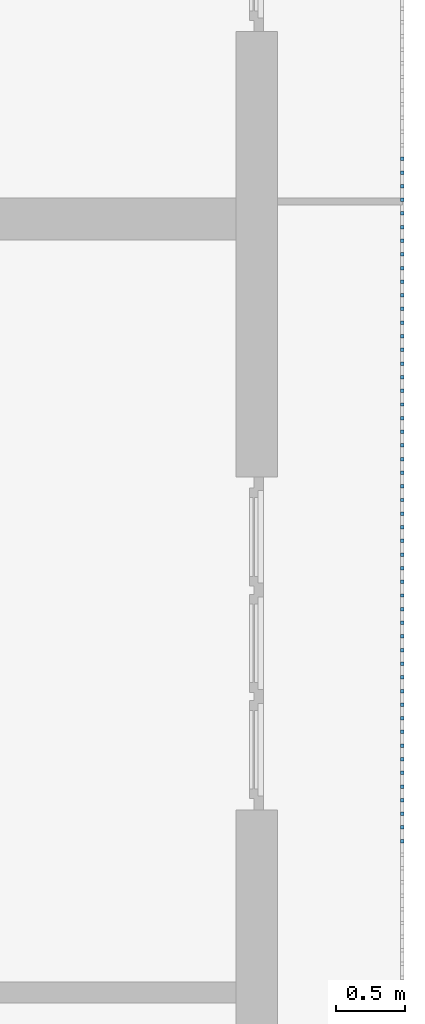
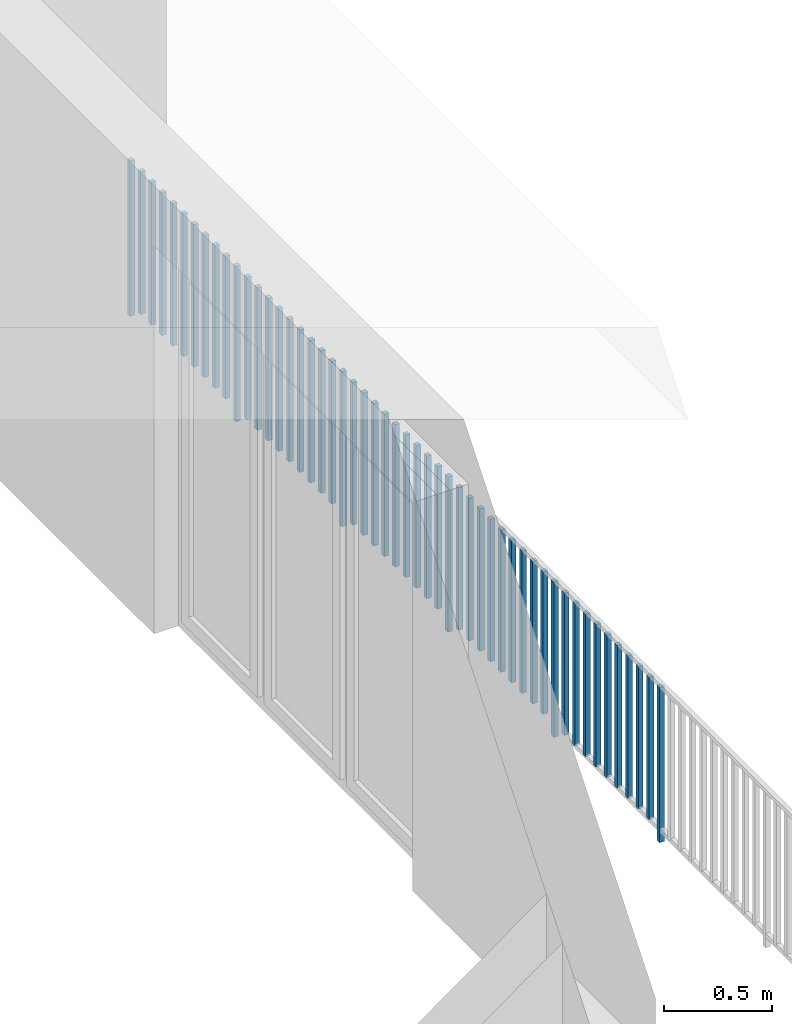
# One storey, part 45 of 54: 51 building element parts, 1 element without a shape of its own.
"""IFC4 building model written with IfcOpenShell, lengths in metres."""

from ifc_helpers import new_model, entity, si_unit, converted_unit, derived_unit, direction, frame, origin_with_axes, place, context, subcontext, project, spatial, polygons, material, type_object, element, aggregate, save


model = new_model("IFC4")

# Units and contexts
model_context = context("Model", 3, precision=1e-05, world=origin_with_axes(), true_north=direction((0.0, 1.0)))
body_context = subcontext(model_context, "Body", "Model", "MODEL_VIEW")
ifc_project = project(units=[si_unit("LENGTHUNIT", "METRE"), si_unit("AREAUNIT", "SQUARE_METRE"), si_unit("VOLUMEUNIT", "CUBIC_METRE"), converted_unit("PLANEANGLEUNIT", "DEGREE", entity("IfcPlaneAngleMeasure", 0.0174532925199), si_unit("PLANEANGLEUNIT", "RADIAN"), dimensions=[0, 0, 0, 0, 0, 0, 0]), converted_unit("TIMEUNIT", "Year", entity("IfcTimeMeasure", 31556926.0), si_unit("TIMEUNIT", "SECOND"), dimensions=[0, 0, 1, 0, 0, 0, 0]), si_unit("MASSUNIT", "GRAM", prefix="KILO"), si_unit("THERMODYNAMICTEMPERATUREUNIT", "DEGREE_CELSIUS"), si_unit("LUMINOUSINTENSITYUNIT", "LUMEN"), si_unit("ENERGYUNIT", "JOULE", prefix="MEGA"), derived_unit("THERMALCONDUCTANCEUNIT", [(si_unit("POWERUNIT", "WATT"), 1), (si_unit("LENGTHUNIT", "METRE"), -1), (si_unit("THERMODYNAMICTEMPERATUREUNIT", "KELVIN"), -1)]), derived_unit("SPECIFICHEATCAPACITYUNIT", [(si_unit("ENERGYUNIT", "JOULE"), 1), (si_unit("MASSUNIT", "GRAM", prefix="KILO"), -1), (si_unit("THERMODYNAMICTEMPERATUREUNIT", "KELVIN"), -1)]), derived_unit("MASSDENSITYUNIT", [(si_unit("MASSUNIT", "GRAM", prefix="KILO"), 1), (si_unit("VOLUMEUNIT", "CUBIC_METRE"), -1)])], contexts=[model_context])

# Site, building, storey, space
site_placement = place(None, origin_with_axes())
site = spatial("IfcSite", under=ifc_project, at=site_placement, CompositionType="ELEMENT")
building_placement = place(site_placement, origin_with_axes())
building = spatial("IfcBuilding", under=site, at=building_placement, CompositionType="ELEMENT")
storey_placement = place(building_placement, frame((0.0, 0.0, 6.29), z_axis=(0.0, 0.0, 1.0), x_axis=(1.0, 0.0, 0.0)))
storey = spatial("IfcBuildingStorey", under=building, at=storey_placement, Name="2. Geschoss", CompositionType="ELEMENT", Elevation=6.29)
space_placement = place(storey_placement, frame((10.2378006196, 9.82118769833, 0.0), z_axis=(0.0, 0.0, 1.0), x_axis=(-1.0, 0.0, 0.0)))
space = spatial("IfcSpace", under=storey, at=space_placement, CompositionType="ELEMENT", PredefinedType="EXTERNAL")

# Railing, building element parts
railing_type = type_object("IfcRailingType", PredefinedType="NOTDEFINED")
railing_placement = place(space_placement, frame((0.0, -7.06315681498e-08, 0.0), z_axis=(0.0, 0.0, 1.0), x_axis=(-1.0, 0.0, 0.0)))
railing = element("IfcRailing", 1, at=railing_placement, inside=space, type_object=railing_type, PredefinedType="NOTDEFINED")
ifc_material = material()
building_element_part_1_placement = place(railing_placement, origin_with_axes())
building_element_part_1 = element("IfcBuildingElementPart", 2, at=building_element_part_1_placement, material=ifc_material, PredefinedType="NOTDEFINED", context=body_context, shape_type="Tessellation", body=[
    polygons([(0.0125, -12.7708333333, 0.0), (-0.0125, -12.7708333333, 0.0), (-0.0125, -12.7708333333, 0.88), (0.0125, -12.7708333333, 0.88), (0.0125, -12.7958333333, 0.0), (-0.0125, -12.7958333333, 0.0), (-0.0125, -12.7958333333, 0.88), (0.0125, -12.7958333333, 0.88)], [[[1, 2, 3, 4]], [[1, 5, 6, 2]], [[2, 6, 7, 3]], [[4, 3, 7, 8]], [[5, 1, 4, 8]], [[6, 5, 8, 7]]], closed=True),
])
building_element_part_2_placement = place(railing_placement, origin_with_axes())
building_element_part_2 = element("IfcBuildingElementPart", 3, at=building_element_part_2_placement, material=ifc_material, PredefinedType="NOTDEFINED", context=body_context, shape_type="Tessellation", body=[
    polygons([(0.0125, -12.6725, 0.07), (-0.0125, -12.6725, 0.07), (-0.0125, -12.6725, 0.8775), (0.0125, -12.6725, 0.8775), (0.0125, -12.6975, 0.07), (-0.0125, -12.6975, 0.07), (-0.0125, -12.6975, 0.8775), (0.0125, -12.6975, 0.8775)], [[[1, 2, 3, 4]], [[1, 5, 6, 2]], [[2, 6, 7, 3]], [[4, 3, 7, 8]], [[5, 1, 4, 8]], [[6, 5, 8, 7]]], closed=True),
])
building_element_part_3_placement = place(railing_placement, origin_with_axes())
building_element_part_3 = element("IfcBuildingElementPart", 4, at=building_element_part_3_placement, material=ifc_material, PredefinedType="NOTDEFINED", context=body_context, shape_type="Tessellation", body=[
    polygons([(0.0125, -12.5741666667, 0.07), (-0.0125, -12.5741666667, 0.07), (-0.0125, -12.5741666667, 0.8775), (0.0125, -12.5741666667, 0.8775), (0.0125, -12.5991666667, 0.07), (-0.0125, -12.5991666667, 0.07), (-0.0125, -12.5991666667, 0.8775), (0.0125, -12.5991666667, 0.8775)], [[[1, 2, 3, 4]], [[1, 5, 6, 2]], [[2, 6, 7, 3]], [[4, 3, 7, 8]], [[5, 1, 4, 8]], [[6, 5, 8, 7]]], closed=True),
])
building_element_part_4_placement = place(railing_placement, origin_with_axes())
building_element_part_4 = element("IfcBuildingElementPart", 5, at=building_element_part_4_placement, material=ifc_material, PredefinedType="NOTDEFINED", context=body_context, shape_type="Tessellation", body=[
    polygons([(0.0125, -12.4758333333, 0.07), (-0.0125, -12.4758333333, 0.07), (-0.0125, -12.4758333333, 0.8775), (0.0125, -12.4758333333, 0.8775), (0.0125, -12.5008333333, 0.07), (-0.0125, -12.5008333333, 0.07), (-0.0125, -12.5008333333, 0.8775), (0.0125, -12.5008333333, 0.8775)], [[[1, 2, 3, 4]], [[1, 5, 6, 2]], [[2, 6, 7, 3]], [[4, 3, 7, 8]], [[5, 1, 4, 8]], [[6, 5, 8, 7]]], closed=True),
])
building_element_part_5_placement = place(railing_placement, origin_with_axes())
building_element_part_5 = element("IfcBuildingElementPart", 6, at=building_element_part_5_placement, material=ifc_material, PredefinedType="NOTDEFINED", context=body_context, shape_type="Tessellation", body=[
    polygons([(0.0125, -12.3775, 0.07), (-0.0125, -12.3775, 0.07), (-0.0125, -12.3775, 0.8775), (0.0125, -12.3775, 0.8775), (0.0125, -12.4025, 0.07), (-0.0125, -12.4025, 0.07), (-0.0125, -12.4025, 0.8775), (0.0125, -12.4025, 0.8775)], [[[1, 2, 3, 4]], [[1, 5, 6, 2]], [[2, 6, 7, 3]], [[4, 3, 7, 8]], [[5, 1, 4, 8]], [[6, 5, 8, 7]]], closed=True),
])
building_element_part_6_placement = place(railing_placement, origin_with_axes())
building_element_part_6 = element("IfcBuildingElementPart", 7, at=building_element_part_6_placement, material=ifc_material, PredefinedType="NOTDEFINED", context=body_context, shape_type="Tessellation", body=[
    polygons([(0.0125, -12.2791666667, 0.07), (-0.0125, -12.2791666667, 0.07), (-0.0125, -12.2791666667, 0.8775), (0.0125, -12.2791666667, 0.8775), (0.0125, -12.3041666667, 0.07), (-0.0125, -12.3041666667, 0.07), (-0.0125, -12.3041666667, 0.8775), (0.0125, -12.3041666667, 0.8775)], [[[1, 2, 3, 4]], [[1, 5, 6, 2]], [[2, 6, 7, 3]], [[4, 3, 7, 8]], [[5, 1, 4, 8]], [[6, 5, 8, 7]]], closed=True),
])
building_element_part_7_placement = place(railing_placement, origin_with_axes())
building_element_part_7 = element("IfcBuildingElementPart", 8, at=building_element_part_7_placement, material=ifc_material, PredefinedType="NOTDEFINED", context=body_context, shape_type="Tessellation", body=[
    polygons([(0.0125, -12.1808333333, 0.07), (-0.0125, -12.1808333333, 0.07), (-0.0125, -12.1808333333, 0.8775), (0.0125, -12.1808333333, 0.8775), (0.0125, -12.2058333333, 0.07), (-0.0125, -12.2058333333, 0.07), (-0.0125, -12.2058333333, 0.8775), (0.0125, -12.2058333333, 0.8775)], [[[1, 2, 3, 4]], [[1, 5, 6, 2]], [[2, 6, 7, 3]], [[4, 3, 7, 8]], [[5, 1, 4, 8]], [[6, 5, 8, 7]]], closed=True),
])
building_element_part_8_placement = place(railing_placement, origin_with_axes())
building_element_part_8 = element("IfcBuildingElementPart", 9, at=building_element_part_8_placement, material=ifc_material, PredefinedType="NOTDEFINED", context=body_context, shape_type="Tessellation", body=[
    polygons([(0.0125, -12.0825, 0.07), (-0.0125, -12.0825, 0.07), (-0.0125, -12.0825, 0.8775), (0.0125, -12.0825, 0.8775), (0.0125, -12.1075, 0.07), (-0.0125, -12.1075, 0.07), (-0.0125, -12.1075, 0.8775), (0.0125, -12.1075, 0.8775)], [[[1, 2, 3, 4]], [[1, 5, 6, 2]], [[2, 6, 7, 3]], [[4, 3, 7, 8]], [[5, 1, 4, 8]], [[6, 5, 8, 7]]], closed=True),
])
building_element_part_9_placement = place(railing_placement, origin_with_axes())
building_element_part_9 = element("IfcBuildingElementPart", 10, at=building_element_part_9_placement, material=ifc_material, PredefinedType="NOTDEFINED", context=body_context, shape_type="Tessellation", body=[
    polygons([(0.0125, -11.9841666667, 0.07), (-0.0125, -11.9841666667, 0.07), (-0.0125, -11.9841666667, 0.8775), (0.0125, -11.9841666667, 0.8775), (0.0125, -12.0091666667, 0.07), (-0.0125, -12.0091666667, 0.07), (-0.0125, -12.0091666667, 0.8775), (0.0125, -12.0091666667, 0.8775)], [[[1, 2, 3, 4]], [[1, 5, 6, 2]], [[2, 6, 7, 3]], [[4, 3, 7, 8]], [[5, 1, 4, 8]], [[6, 5, 8, 7]]], closed=True),
])
building_element_part_10_placement = place(railing_placement, origin_with_axes())
building_element_part_10 = element("IfcBuildingElementPart", 11, at=building_element_part_10_placement, material=ifc_material, PredefinedType="NOTDEFINED", context=body_context, shape_type="Tessellation", body=[
    polygons([(0.0125, -11.8858333333, 0.07), (-0.0125, -11.8858333333, 0.07), (-0.0125, -11.8858333333, 0.8775), (0.0125, -11.8858333333, 0.8775), (0.0125, -11.9108333333, 0.07), (-0.0125, -11.9108333333, 0.07), (-0.0125, -11.9108333333, 0.8775), (0.0125, -11.9108333333, 0.8775)], [[[1, 2, 3, 4]], [[1, 5, 6, 2]], [[2, 6, 7, 3]], [[4, 3, 7, 8]], [[5, 1, 4, 8]], [[6, 5, 8, 7]]], closed=True),
])
building_element_part_11_placement = place(railing_placement, origin_with_axes())
building_element_part_11 = element("IfcBuildingElementPart", 12, at=building_element_part_11_placement, material=ifc_material, PredefinedType="NOTDEFINED", context=body_context, shape_type="Tessellation", body=[
    polygons([(0.0125, -11.7875, 0.0), (-0.0125, -11.7875, 0.0), (-0.0125, -11.7875, 0.88), (0.0125, -11.7875, 0.88), (0.0125, -11.8125, 0.0), (-0.0125, -11.8125, 0.0), (-0.0125, -11.8125, 0.88), (0.0125, -11.8125, 0.88)], [[[1, 2, 3, 4]], [[1, 5, 6, 2]], [[2, 6, 7, 3]], [[4, 3, 7, 8]], [[5, 1, 4, 8]], [[6, 5, 8, 7]]], closed=True),
])
building_element_part_12_placement = place(railing_placement, origin_with_axes())
building_element_part_12 = element("IfcBuildingElementPart", 13, at=building_element_part_12_placement, material=ifc_material, PredefinedType="NOTDEFINED", context=body_context, shape_type="Tessellation", body=[
    polygons([(0.0125, -11.6891666667, 0.07), (-0.0125, -11.6891666667, 0.07), (-0.0125, -11.6891666667, 0.8775), (0.0125, -11.6891666667, 0.8775), (0.0125, -11.7141666667, 0.07), (-0.0125, -11.7141666667, 0.07), (-0.0125, -11.7141666667, 0.8775), (0.0125, -11.7141666667, 0.8775)], [[[1, 2, 3, 4]], [[1, 5, 6, 2]], [[2, 6, 7, 3]], [[4, 3, 7, 8]], [[5, 1, 4, 8]], [[6, 5, 8, 7]]], closed=True),
])
building_element_part_13_placement = place(railing_placement, origin_with_axes())
building_element_part_13 = element("IfcBuildingElementPart", 14, at=building_element_part_13_placement, material=ifc_material, PredefinedType="NOTDEFINED", context=body_context, shape_type="Tessellation", body=[
    polygons([(0.0125, -11.5908333333, 0.07), (-0.0125, -11.5908333333, 0.07), (-0.0125, -11.5908333333, 0.8775), (0.0125, -11.5908333333, 0.8775), (0.0125, -11.6158333333, 0.07), (-0.0125, -11.6158333333, 0.07), (-0.0125, -11.6158333333, 0.8775), (0.0125, -11.6158333333, 0.8775)], [[[1, 2, 3, 4]], [[1, 5, 6, 2]], [[2, 6, 7, 3]], [[4, 3, 7, 8]], [[5, 1, 4, 8]], [[6, 5, 8, 7]]], closed=True),
])
building_element_part_14_placement = place(railing_placement, origin_with_axes())
building_element_part_14 = element("IfcBuildingElementPart", 15, at=building_element_part_14_placement, material=ifc_material, PredefinedType="NOTDEFINED", context=body_context, shape_type="Tessellation", body=[
    polygons([(0.0125, -11.4925, 0.07), (-0.0125, -11.4925, 0.07), (-0.0125, -11.4925, 0.8775), (0.0125, -11.4925, 0.8775), (0.0125, -11.5175, 0.07), (-0.0125, -11.5175, 0.07), (-0.0125, -11.5175, 0.8775), (0.0125, -11.5175, 0.8775)], [[[1, 2, 3, 4]], [[1, 5, 6, 2]], [[2, 6, 7, 3]], [[4, 3, 7, 8]], [[5, 1, 4, 8]], [[6, 5, 8, 7]]], closed=True),
])
building_element_part_15_placement = place(railing_placement, origin_with_axes())
building_element_part_15 = element("IfcBuildingElementPart", 16, at=building_element_part_15_placement, material=ifc_material, PredefinedType="NOTDEFINED", context=body_context, shape_type="Tessellation", body=[
    polygons([(0.0125, -11.3941666667, 0.07), (-0.0125, -11.3941666667, 0.07), (-0.0125, -11.3941666667, 0.8775), (0.0125, -11.3941666667, 0.8775), (0.0125, -11.4191666667, 0.07), (-0.0125, -11.4191666667, 0.07), (-0.0125, -11.4191666667, 0.8775), (0.0125, -11.4191666667, 0.8775)], [[[1, 2, 3, 4]], [[1, 5, 6, 2]], [[2, 6, 7, 3]], [[4, 3, 7, 8]], [[5, 1, 4, 8]], [[6, 5, 8, 7]]], closed=True),
])
building_element_part_16_placement = place(railing_placement, origin_with_axes())
building_element_part_16 = element("IfcBuildingElementPart", 17, at=building_element_part_16_placement, material=ifc_material, PredefinedType="NOTDEFINED", context=body_context, shape_type="Tessellation", body=[
    polygons([(0.0125, -11.2958333333, 0.07), (-0.0125, -11.2958333333, 0.07), (-0.0125, -11.2958333333, 0.8775), (0.0125, -11.2958333333, 0.8775), (0.0125, -11.3208333333, 0.07), (-0.0125, -11.3208333333, 0.07), (-0.0125, -11.3208333333, 0.8775), (0.0125, -11.3208333333, 0.8775)], [[[1, 2, 3, 4]], [[1, 5, 6, 2]], [[2, 6, 7, 3]], [[4, 3, 7, 8]], [[5, 1, 4, 8]], [[6, 5, 8, 7]]], closed=True),
])
building_element_part_17_placement = place(railing_placement, origin_with_axes())
building_element_part_17 = element("IfcBuildingElementPart", 18, at=building_element_part_17_placement, material=ifc_material, PredefinedType="NOTDEFINED", context=body_context, shape_type="Tessellation", body=[
    polygons([(0.0125, -11.1975, 0.07), (-0.0125, -11.1975, 0.07), (-0.0125, -11.1975, 0.8775), (0.0125, -11.1975, 0.8775), (0.0125, -11.2225, 0.07), (-0.0125, -11.2225, 0.07), (-0.0125, -11.2225, 0.8775), (0.0125, -11.2225, 0.8775)], [[[1, 2, 3, 4]], [[1, 5, 6, 2]], [[2, 6, 7, 3]], [[4, 3, 7, 8]], [[5, 1, 4, 8]], [[6, 5, 8, 7]]], closed=True),
])
building_element_part_18_placement = place(railing_placement, origin_with_axes())
building_element_part_18 = element("IfcBuildingElementPart", 19, at=building_element_part_18_placement, material=ifc_material, PredefinedType="NOTDEFINED", context=body_context, shape_type="Tessellation", body=[
    polygons([(0.0125, -11.0991666667, 0.07), (-0.0125, -11.0991666667, 0.07), (-0.0125, -11.0991666667, 0.8775), (0.0125, -11.0991666667, 0.8775), (0.0125, -11.1241666667, 0.07), (-0.0125, -11.1241666667, 0.07), (-0.0125, -11.1241666667, 0.8775), (0.0125, -11.1241666667, 0.8775)], [[[1, 2, 3, 4]], [[1, 5, 6, 2]], [[2, 6, 7, 3]], [[4, 3, 7, 8]], [[5, 1, 4, 8]], [[6, 5, 8, 7]]], closed=True),
])
building_element_part_19_placement = place(railing_placement, origin_with_axes())
building_element_part_19 = element("IfcBuildingElementPart", 20, at=building_element_part_19_placement, material=ifc_material, PredefinedType="NOTDEFINED", context=body_context, shape_type="Tessellation", body=[
    polygons([(0.0125, -11.0008333333, 0.07), (-0.0125, -11.0008333333, 0.07), (-0.0125, -11.0008333333, 0.8775), (0.0125, -11.0008333333, 0.8775), (0.0125, -11.0258333333, 0.07), (-0.0125, -11.0258333333, 0.07), (-0.0125, -11.0258333333, 0.8775), (0.0125, -11.0258333333, 0.8775)], [[[1, 2, 3, 4]], [[1, 5, 6, 2]], [[2, 6, 7, 3]], [[4, 3, 7, 8]], [[5, 1, 4, 8]], [[6, 5, 8, 7]]], closed=True),
])
building_element_part_20_placement = place(railing_placement, origin_with_axes())
building_element_part_20 = element("IfcBuildingElementPart", 21, at=building_element_part_20_placement, material=ifc_material, PredefinedType="NOTDEFINED", context=body_context, shape_type="Tessellation", body=[
    polygons([(0.0125, -10.9025, 0.07), (-0.0125, -10.9025, 0.07), (-0.0125, -10.9025, 0.8775), (0.0125, -10.9025, 0.8775), (0.0125, -10.9275, 0.07), (-0.0125, -10.9275, 0.07), (-0.0125, -10.9275, 0.8775), (0.0125, -10.9275, 0.8775)], [[[1, 2, 3, 4]], [[1, 5, 6, 2]], [[2, 6, 7, 3]], [[4, 3, 7, 8]], [[5, 1, 4, 8]], [[6, 5, 8, 7]]], closed=True),
])
building_element_part_21_placement = place(railing_placement, origin_with_axes())
building_element_part_21 = element("IfcBuildingElementPart", 22, at=building_element_part_21_placement, material=ifc_material, PredefinedType="NOTDEFINED", context=body_context, shape_type="Tessellation", body=[
    polygons([(0.0125, -10.8041666667, 0.0), (-0.0125, -10.8041666667, 0.0), (-0.0125, -10.8041666667, 0.88), (0.0125, -10.8041666667, 0.88), (0.0125, -10.8291666667, 0.0), (-0.0125, -10.8291666667, 0.0), (-0.0125, -10.8291666667, 0.88), (0.0125, -10.8291666667, 0.88)], [[[1, 2, 3, 4]], [[1, 5, 6, 2]], [[2, 6, 7, 3]], [[4, 3, 7, 8]], [[5, 1, 4, 8]], [[6, 5, 8, 7]]], closed=True),
])
building_element_part_22_placement = place(railing_placement, origin_with_axes())
building_element_part_22 = element("IfcBuildingElementPart", 23, at=building_element_part_22_placement, material=ifc_material, PredefinedType="NOTDEFINED", context=body_context, shape_type="Tessellation", body=[
    polygons([(0.0125, -10.7058333333, 0.07), (-0.0125, -10.7058333333, 0.07), (-0.0125, -10.7058333333, 0.8775), (0.0125, -10.7058333333, 0.8775), (0.0125, -10.7308333333, 0.07), (-0.0125, -10.7308333333, 0.07), (-0.0125, -10.7308333333, 0.8775), (0.0125, -10.7308333333, 0.8775)], [[[1, 2, 3, 4]], [[1, 5, 6, 2]], [[2, 6, 7, 3]], [[4, 3, 7, 8]], [[5, 1, 4, 8]], [[6, 5, 8, 7]]], closed=True),
])
building_element_part_23_placement = place(railing_placement, origin_with_axes())
building_element_part_23 = element("IfcBuildingElementPart", 24, at=building_element_part_23_placement, material=ifc_material, PredefinedType="NOTDEFINED", context=body_context, shape_type="Tessellation", body=[
    polygons([(0.0125, -10.6075, 0.07), (-0.0125, -10.6075, 0.07), (-0.0125, -10.6075, 0.8775), (0.0125, -10.6075, 0.8775), (0.0125, -10.6325, 0.07), (-0.0125, -10.6325, 0.07), (-0.0125, -10.6325, 0.8775), (0.0125, -10.6325, 0.8775)], [[[1, 2, 3, 4]], [[1, 5, 6, 2]], [[2, 6, 7, 3]], [[4, 3, 7, 8]], [[5, 1, 4, 8]], [[6, 5, 8, 7]]], closed=True),
])
building_element_part_24_placement = place(railing_placement, origin_with_axes())
building_element_part_24 = element("IfcBuildingElementPart", 25, at=building_element_part_24_placement, material=ifc_material, PredefinedType="NOTDEFINED", context=body_context, shape_type="Tessellation", body=[
    polygons([(0.0125, -10.5091666667, 0.07), (-0.0125, -10.5091666667, 0.07), (-0.0125, -10.5091666667, 0.8775), (0.0125, -10.5091666667, 0.8775), (0.0125, -10.5341666667, 0.07), (-0.0125, -10.5341666667, 0.07), (-0.0125, -10.5341666667, 0.8775), (0.0125, -10.5341666667, 0.8775)], [[[1, 2, 3, 4]], [[1, 5, 6, 2]], [[2, 6, 7, 3]], [[4, 3, 7, 8]], [[5, 1, 4, 8]], [[6, 5, 8, 7]]], closed=True),
])
building_element_part_25_placement = place(railing_placement, origin_with_axes())
building_element_part_25 = element("IfcBuildingElementPart", 26, at=building_element_part_25_placement, material=ifc_material, PredefinedType="NOTDEFINED", context=body_context, shape_type="Tessellation", body=[
    polygons([(0.0125, -10.4108333333, 0.07), (-0.0125, -10.4108333333, 0.07), (-0.0125, -10.4108333333, 0.8775), (0.0125, -10.4108333333, 0.8775), (0.0125, -10.4358333333, 0.07), (-0.0125, -10.4358333333, 0.07), (-0.0125, -10.4358333333, 0.8775), (0.0125, -10.4358333333, 0.8775)], [[[1, 2, 3, 4]], [[1, 5, 6, 2]], [[2, 6, 7, 3]], [[4, 3, 7, 8]], [[5, 1, 4, 8]], [[6, 5, 8, 7]]], closed=True),
])
building_element_part_26_placement = place(railing_placement, origin_with_axes())
building_element_part_26 = element("IfcBuildingElementPart", 27, at=building_element_part_26_placement, material=ifc_material, PredefinedType="NOTDEFINED", context=body_context, shape_type="Tessellation", body=[
    polygons([(0.0125, -10.3125, 0.07), (-0.0125, -10.3125, 0.07), (-0.0125, -10.3125, 0.8775), (0.0125, -10.3125, 0.8775), (0.0125, -10.3375, 0.07), (-0.0125, -10.3375, 0.07), (-0.0125, -10.3375, 0.8775), (0.0125, -10.3375, 0.8775)], [[[1, 2, 3, 4]], [[1, 5, 6, 2]], [[2, 6, 7, 3]], [[4, 3, 7, 8]], [[5, 1, 4, 8]], [[6, 5, 8, 7]]], closed=True),
])
building_element_part_27_placement = place(railing_placement, origin_with_axes())
building_element_part_27 = element("IfcBuildingElementPart", 28, at=building_element_part_27_placement, material=ifc_material, PredefinedType="NOTDEFINED", context=body_context, shape_type="Tessellation", body=[
    polygons([(0.0125, -10.2141666667, 0.07), (-0.0125, -10.2141666667, 0.07), (-0.0125, -10.2141666667, 0.8775), (0.0125, -10.2141666667, 0.8775), (0.0125, -10.2391666667, 0.07), (-0.0125, -10.2391666667, 0.07), (-0.0125, -10.2391666667, 0.8775), (0.0125, -10.2391666667, 0.8775)], [[[1, 2, 3, 4]], [[1, 5, 6, 2]], [[2, 6, 7, 3]], [[4, 3, 7, 8]], [[5, 1, 4, 8]], [[6, 5, 8, 7]]], closed=True),
])
building_element_part_28_placement = place(railing_placement, origin_with_axes())
building_element_part_28 = element("IfcBuildingElementPart", 29, at=building_element_part_28_placement, material=ifc_material, PredefinedType="NOTDEFINED", context=body_context, shape_type="Tessellation", body=[
    polygons([(0.0125, -10.1158333333, 0.07), (-0.0125, -10.1158333333, 0.07), (-0.0125, -10.1158333333, 0.8775), (0.0125, -10.1158333333, 0.8775), (0.0125, -10.1408333333, 0.07), (-0.0125, -10.1408333333, 0.07), (-0.0125, -10.1408333333, 0.8775), (0.0125, -10.1408333333, 0.8775)], [[[1, 2, 3, 4]], [[1, 5, 6, 2]], [[2, 6, 7, 3]], [[4, 3, 7, 8]], [[5, 1, 4, 8]], [[6, 5, 8, 7]]], closed=True),
])
building_element_part_29_placement = place(railing_placement, origin_with_axes())
building_element_part_29 = element("IfcBuildingElementPart", 30, at=building_element_part_29_placement, material=ifc_material, PredefinedType="NOTDEFINED", context=body_context, shape_type="Tessellation", body=[
    polygons([(0.0125, -10.0175, 0.07), (-0.0125, -10.0175, 0.07), (-0.0125, -10.0175, 0.8775), (0.0125, -10.0175, 0.8775), (0.0125, -10.0425, 0.07), (-0.0125, -10.0425, 0.07), (-0.0125, -10.0425, 0.8775), (0.0125, -10.0425, 0.8775)], [[[1, 2, 3, 4]], [[1, 5, 6, 2]], [[2, 6, 7, 3]], [[4, 3, 7, 8]], [[5, 1, 4, 8]], [[6, 5, 8, 7]]], closed=True),
])
building_element_part_30_placement = place(railing_placement, origin_with_axes())
building_element_part_30 = element("IfcBuildingElementPart", 31, at=building_element_part_30_placement, material=ifc_material, PredefinedType="NOTDEFINED", context=body_context, shape_type="Tessellation", body=[
    polygons([(0.0125, -9.91916666667, 0.07), (-0.0125, -9.91916666667, 0.07), (-0.0125, -9.91916666667, 0.8775), (0.0125, -9.91916666667, 0.8775), (0.0125, -9.94416666667, 0.07), (-0.0125, -9.94416666667, 0.07), (-0.0125, -9.94416666667, 0.8775), (0.0125, -9.94416666667, 0.8775)], [[[1, 2, 3, 4]], [[1, 5, 6, 2]], [[2, 6, 7, 3]], [[4, 3, 7, 8]], [[5, 1, 4, 8]], [[6, 5, 8, 7]]], closed=True),
])
building_element_part_31_placement = place(railing_placement, origin_with_axes())
building_element_part_31 = element("IfcBuildingElementPart", 32, at=building_element_part_31_placement, material=ifc_material, PredefinedType="NOTDEFINED", context=body_context, shape_type="Tessellation", body=[
    polygons([(0.0125, -9.82083333333, 0.0), (-0.0125, -9.82083333333, 0.0), (-0.0125, -9.82083333333, 0.88), (0.0125, -9.82083333333, 0.88), (0.0125, -9.84583333333, 0.0), (-0.0125, -9.84583333333, 0.0), (-0.0125, -9.84583333333, 0.88), (0.0125, -9.84583333333, 0.88)], [[[1, 2, 3, 4]], [[1, 5, 6, 2]], [[2, 6, 7, 3]], [[4, 3, 7, 8]], [[5, 1, 4, 8]], [[6, 5, 8, 7]]], closed=True),
])
building_element_part_32_placement = place(railing_placement, origin_with_axes())
building_element_part_32 = element("IfcBuildingElementPart", 33, at=building_element_part_32_placement, material=ifc_material, PredefinedType="NOTDEFINED", context=body_context, shape_type="Tessellation", body=[
    polygons([(0.0125, -9.7225, 0.07), (-0.0125, -9.7225, 0.07), (-0.0125, -9.7225, 0.8775), (0.0125, -9.7225, 0.8775), (0.0125, -9.7475, 0.07), (-0.0125, -9.7475, 0.07), (-0.0125, -9.7475, 0.8775), (0.0125, -9.7475, 0.8775)], [[[1, 2, 3, 4]], [[1, 5, 6, 2]], [[2, 6, 7, 3]], [[4, 3, 7, 8]], [[5, 1, 4, 8]], [[6, 5, 8, 7]]], closed=True),
])
building_element_part_33_placement = place(railing_placement, origin_with_axes())
building_element_part_33 = element("IfcBuildingElementPart", 34, at=building_element_part_33_placement, material=ifc_material, PredefinedType="NOTDEFINED", context=body_context, shape_type="Tessellation", body=[
    polygons([(0.0125, -9.62416666667, 0.07), (-0.0125, -9.62416666667, 0.07), (-0.0125, -9.62416666667, 0.8775), (0.0125, -9.62416666667, 0.8775), (0.0125, -9.64916666667, 0.07), (-0.0125, -9.64916666667, 0.07), (-0.0125, -9.64916666667, 0.8775), (0.0125, -9.64916666667, 0.8775)], [[[1, 2, 3, 4]], [[1, 5, 6, 2]], [[2, 6, 7, 3]], [[4, 3, 7, 8]], [[5, 1, 4, 8]], [[6, 5, 8, 7]]], closed=True),
])
building_element_part_34_placement = place(railing_placement, origin_with_axes())
building_element_part_34 = element("IfcBuildingElementPart", 35, at=building_element_part_34_placement, material=ifc_material, PredefinedType="NOTDEFINED", context=body_context, shape_type="Tessellation", body=[
    polygons([(0.0125, -9.52583333333, 0.07), (-0.0125, -9.52583333333, 0.07), (-0.0125, -9.52583333333, 0.8775), (0.0125, -9.52583333333, 0.8775), (0.0125, -9.55083333333, 0.07), (-0.0125, -9.55083333333, 0.07), (-0.0125, -9.55083333333, 0.8775), (0.0125, -9.55083333333, 0.8775)], [[[1, 2, 3, 4]], [[1, 5, 6, 2]], [[2, 6, 7, 3]], [[4, 3, 7, 8]], [[5, 1, 4, 8]], [[6, 5, 8, 7]]], closed=True),
])
building_element_part_35_placement = place(railing_placement, origin_with_axes())
building_element_part_35 = element("IfcBuildingElementPart", 36, at=building_element_part_35_placement, material=ifc_material, PredefinedType="NOTDEFINED", context=body_context, shape_type="Tessellation", body=[
    polygons([(0.0125, -9.4275, 0.07), (-0.0125, -9.4275, 0.07), (-0.0125, -9.4275, 0.8775), (0.0125, -9.4275, 0.8775), (0.0125, -9.4525, 0.07), (-0.0125, -9.4525, 0.07), (-0.0125, -9.4525, 0.8775), (0.0125, -9.4525, 0.8775)], [[[1, 2, 3, 4]], [[1, 5, 6, 2]], [[2, 6, 7, 3]], [[4, 3, 7, 8]], [[5, 1, 4, 8]], [[6, 5, 8, 7]]], closed=True),
])
building_element_part_36_placement = place(railing_placement, origin_with_axes())
building_element_part_36 = element("IfcBuildingElementPart", 37, at=building_element_part_36_placement, material=ifc_material, PredefinedType="NOTDEFINED", context=body_context, shape_type="Tessellation", body=[
    polygons([(0.0125, -9.32916666667, 0.07), (-0.0125, -9.32916666667, 0.07), (-0.0125, -9.32916666667, 0.8775), (0.0125, -9.32916666667, 0.8775), (0.0125, -9.35416666667, 0.07), (-0.0125, -9.35416666667, 0.07), (-0.0125, -9.35416666667, 0.8775), (0.0125, -9.35416666667, 0.8775)], [[[1, 2, 3, 4]], [[1, 5, 6, 2]], [[2, 6, 7, 3]], [[4, 3, 7, 8]], [[5, 1, 4, 8]], [[6, 5, 8, 7]]], closed=True),
])
building_element_part_37_placement = place(railing_placement, origin_with_axes())
building_element_part_37 = element("IfcBuildingElementPart", 38, at=building_element_part_37_placement, material=ifc_material, PredefinedType="NOTDEFINED", context=body_context, shape_type="Tessellation", body=[
    polygons([(0.0125, -9.23083333333, 0.07), (-0.0125, -9.23083333333, 0.07), (-0.0125, -9.23083333333, 0.8775), (0.0125, -9.23083333333, 0.8775), (0.0125, -9.25583333333, 0.07), (-0.0125, -9.25583333333, 0.07), (-0.0125, -9.25583333333, 0.8775), (0.0125, -9.25583333333, 0.8775)], [[[1, 2, 3, 4]], [[1, 5, 6, 2]], [[2, 6, 7, 3]], [[4, 3, 7, 8]], [[5, 1, 4, 8]], [[6, 5, 8, 7]]], closed=True),
])
building_element_part_38_placement = place(railing_placement, origin_with_axes())
building_element_part_38 = element("IfcBuildingElementPart", 39, at=building_element_part_38_placement, material=ifc_material, PredefinedType="NOTDEFINED", context=body_context, shape_type="Tessellation", body=[
    polygons([(0.0125, -9.1325, 0.07), (-0.0125, -9.1325, 0.07), (-0.0125, -9.1325, 0.8775), (0.0125, -9.1325, 0.8775), (0.0125, -9.1575, 0.07), (-0.0125, -9.1575, 0.07), (-0.0125, -9.1575, 0.8775), (0.0125, -9.1575, 0.8775)], [[[1, 2, 3, 4]], [[1, 5, 6, 2]], [[2, 6, 7, 3]], [[4, 3, 7, 8]], [[5, 1, 4, 8]], [[6, 5, 8, 7]]], closed=True),
])
building_element_part_39_placement = place(railing_placement, origin_with_axes())
building_element_part_39 = element("IfcBuildingElementPart", 40, at=building_element_part_39_placement, material=ifc_material, PredefinedType="NOTDEFINED", context=body_context, shape_type="Tessellation", body=[
    polygons([(0.0125, -9.03416666667, 0.07), (-0.0125, -9.03416666667, 0.07), (-0.0125, -9.03416666667, 0.8775), (0.0125, -9.03416666667, 0.8775), (0.0125, -9.05916666667, 0.07), (-0.0125, -9.05916666667, 0.07), (-0.0125, -9.05916666667, 0.8775), (0.0125, -9.05916666667, 0.8775)], [[[1, 2, 3, 4]], [[1, 5, 6, 2]], [[2, 6, 7, 3]], [[4, 3, 7, 8]], [[5, 1, 4, 8]], [[6, 5, 8, 7]]], closed=True),
])
building_element_part_40_placement = place(railing_placement, origin_with_axes())
building_element_part_40 = element("IfcBuildingElementPart", 41, at=building_element_part_40_placement, material=ifc_material, PredefinedType="NOTDEFINED", context=body_context, shape_type="Tessellation", body=[
    polygons([(0.0125, -8.93583333333, 0.07), (-0.0125, -8.93583333333, 0.07), (-0.0125, -8.93583333333, 0.8775), (0.0125, -8.93583333333, 0.8775), (0.0125, -8.96083333333, 0.07), (-0.0125, -8.96083333333, 0.07), (-0.0125, -8.96083333333, 0.8775), (0.0125, -8.96083333333, 0.8775)], [[[1, 2, 3, 4]], [[1, 5, 6, 2]], [[2, 6, 7, 3]], [[4, 3, 7, 8]], [[5, 1, 4, 8]], [[6, 5, 8, 7]]], closed=True),
])
building_element_part_41_placement = place(railing_placement, origin_with_axes())
building_element_part_41 = element("IfcBuildingElementPart", 42, at=building_element_part_41_placement, material=ifc_material, PredefinedType="NOTDEFINED", context=body_context, shape_type="Tessellation", body=[
    polygons([(0.0125, -8.8375, 0.0), (-0.0125, -8.8375, 0.0), (-0.0125, -8.8375, 0.88), (0.0125, -8.8375, 0.88), (0.0125, -8.8625, 0.0), (-0.0125, -8.8625, 0.0), (-0.0125, -8.8625, 0.88), (0.0125, -8.8625, 0.88)], [[[1, 2, 3, 4]], [[1, 5, 6, 2]], [[2, 6, 7, 3]], [[4, 3, 7, 8]], [[5, 1, 4, 8]], [[6, 5, 8, 7]]], closed=True),
])
building_element_part_42_placement = place(railing_placement, origin_with_axes())
building_element_part_42 = element("IfcBuildingElementPart", 43, at=building_element_part_42_placement, material=ifc_material, PredefinedType="NOTDEFINED", context=body_context, shape_type="Tessellation", body=[
    polygons([(0.0125, -8.73916666667, 0.07), (-0.0125, -8.73916666667, 0.07), (-0.0125, -8.73916666667, 0.8775), (0.0125, -8.73916666667, 0.8775), (0.0125, -8.76416666667, 0.07), (-0.0125, -8.76416666667, 0.07), (-0.0125, -8.76416666667, 0.8775), (0.0125, -8.76416666667, 0.8775)], [[[1, 2, 3, 4]], [[1, 5, 6, 2]], [[2, 6, 7, 3]], [[4, 3, 7, 8]], [[5, 1, 4, 8]], [[6, 5, 8, 7]]], closed=True),
])
building_element_part_43_placement = place(railing_placement, origin_with_axes())
building_element_part_43 = element("IfcBuildingElementPart", 44, at=building_element_part_43_placement, material=ifc_material, PredefinedType="NOTDEFINED", context=body_context, shape_type="Tessellation", body=[
    polygons([(0.0125, -8.64083333333, 0.07), (-0.0125, -8.64083333333, 0.07), (-0.0125, -8.64083333333, 0.8775), (0.0125, -8.64083333333, 0.8775), (0.0125, -8.66583333333, 0.07), (-0.0125, -8.66583333333, 0.07), (-0.0125, -8.66583333333, 0.8775), (0.0125, -8.66583333333, 0.8775)], [[[1, 2, 3, 4]], [[1, 5, 6, 2]], [[2, 6, 7, 3]], [[4, 3, 7, 8]], [[5, 1, 4, 8]], [[6, 5, 8, 7]]], closed=True),
])
building_element_part_44_placement = place(railing_placement, origin_with_axes())
building_element_part_44 = element("IfcBuildingElementPart", 45, at=building_element_part_44_placement, material=ifc_material, PredefinedType="NOTDEFINED", context=body_context, shape_type="Tessellation", body=[
    polygons([(0.0125, -8.5425, 0.07), (-0.0125, -8.5425, 0.07), (-0.0125, -8.5425, 0.8775), (0.0125, -8.5425, 0.8775), (0.0125, -8.5675, 0.07), (-0.0125, -8.5675, 0.07), (-0.0125, -8.5675, 0.8775), (0.0125, -8.5675, 0.8775)], [[[1, 2, 3, 4]], [[1, 5, 6, 2]], [[2, 6, 7, 3]], [[4, 3, 7, 8]], [[5, 1, 4, 8]], [[6, 5, 8, 7]]], closed=True),
])
building_element_part_45_placement = place(railing_placement, origin_with_axes())
building_element_part_45 = element("IfcBuildingElementPart", 46, at=building_element_part_45_placement, material=ifc_material, PredefinedType="NOTDEFINED", context=body_context, shape_type="Tessellation", body=[
    polygons([(0.0125, -8.44416666667, 0.07), (-0.0125, -8.44416666667, 0.07), (-0.0125, -8.44416666667, 0.8775), (0.0125, -8.44416666667, 0.8775), (0.0125, -8.46916666667, 0.07), (-0.0125, -8.46916666667, 0.07), (-0.0125, -8.46916666667, 0.8775), (0.0125, -8.46916666667, 0.8775)], [[[1, 2, 3, 4]], [[1, 5, 6, 2]], [[2, 6, 7, 3]], [[4, 3, 7, 8]], [[5, 1, 4, 8]], [[6, 5, 8, 7]]], closed=True),
])
building_element_part_46_placement = place(railing_placement, origin_with_axes())
building_element_part_46 = element("IfcBuildingElementPart", 47, at=building_element_part_46_placement, material=ifc_material, PredefinedType="NOTDEFINED", context=body_context, shape_type="Tessellation", body=[
    polygons([(0.0125, -8.34583333333, 0.07), (-0.0125, -8.34583333333, 0.07), (-0.0125, -8.34583333333, 0.8775), (0.0125, -8.34583333333, 0.8775), (0.0125, -8.37083333333, 0.07), (-0.0125, -8.37083333333, 0.07), (-0.0125, -8.37083333333, 0.8775), (0.0125, -8.37083333333, 0.8775)], [[[1, 2, 3, 4]], [[1, 5, 6, 2]], [[2, 6, 7, 3]], [[4, 3, 7, 8]], [[5, 1, 4, 8]], [[6, 5, 8, 7]]], closed=True),
])
building_element_part_47_placement = place(railing_placement, origin_with_axes())
building_element_part_47 = element("IfcBuildingElementPart", 48, at=building_element_part_47_placement, material=ifc_material, PredefinedType="NOTDEFINED", context=body_context, shape_type="Tessellation", body=[
    polygons([(0.0125, -8.2475, 0.07), (-0.0125, -8.2475, 0.07), (-0.0125, -8.2475, 0.8775), (0.0125, -8.2475, 0.8775), (0.0125, -8.2725, 0.07), (-0.0125, -8.2725, 0.07), (-0.0125, -8.2725, 0.8775), (0.0125, -8.2725, 0.8775)], [[[1, 2, 3, 4]], [[1, 5, 6, 2]], [[2, 6, 7, 3]], [[4, 3, 7, 8]], [[5, 1, 4, 8]], [[6, 5, 8, 7]]], closed=True),
])
building_element_part_48_placement = place(railing_placement, origin_with_axes())
building_element_part_48 = element("IfcBuildingElementPart", 49, at=building_element_part_48_placement, material=ifc_material, PredefinedType="NOTDEFINED", context=body_context, shape_type="Tessellation", body=[
    polygons([(0.0125, -8.14916666667, 0.07), (-0.0125, -8.14916666667, 0.07), (-0.0125, -8.14916666667, 0.8775), (0.0125, -8.14916666667, 0.8775), (0.0125, -8.17416666667, 0.07), (-0.0125, -8.17416666667, 0.07), (-0.0125, -8.17416666667, 0.8775), (0.0125, -8.17416666667, 0.8775)], [[[1, 2, 3, 4]], [[1, 5, 6, 2]], [[2, 6, 7, 3]], [[4, 3, 7, 8]], [[5, 1, 4, 8]], [[6, 5, 8, 7]]], closed=True),
])
building_element_part_49_placement = place(railing_placement, origin_with_axes())
building_element_part_49 = element("IfcBuildingElementPart", 50, at=building_element_part_49_placement, material=ifc_material, PredefinedType="NOTDEFINED", context=body_context, shape_type="Tessellation", body=[
    polygons([(0.0125, -8.05083333333, 0.07), (-0.0125, -8.05083333333, 0.07), (-0.0125, -8.05083333333, 0.8775), (0.0125, -8.05083333333, 0.8775), (0.0125, -8.07583333333, 0.07), (-0.0125, -8.07583333333, 0.07), (-0.0125, -8.07583333333, 0.8775), (0.0125, -8.07583333333, 0.8775)], [[[1, 2, 3, 4]], [[1, 5, 6, 2]], [[2, 6, 7, 3]], [[4, 3, 7, 8]], [[5, 1, 4, 8]], [[6, 5, 8, 7]]], closed=True),
])
building_element_part_50_placement = place(railing_placement, origin_with_axes())
building_element_part_50 = element("IfcBuildingElementPart", 51, at=building_element_part_50_placement, material=ifc_material, PredefinedType="NOTDEFINED", context=body_context, shape_type="Tessellation", body=[
    polygons([(0.0125, -7.9525, 0.07), (-0.0125, -7.9525, 0.07), (-0.0125, -7.9525, 0.8775), (0.0125, -7.9525, 0.8775), (0.0125, -7.9775, 0.07), (-0.0125, -7.9775, 0.07), (-0.0125, -7.9775, 0.8775), (0.0125, -7.9775, 0.8775)], [[[1, 2, 3, 4]], [[1, 5, 6, 2]], [[2, 6, 7, 3]], [[4, 3, 7, 8]], [[5, 1, 4, 8]], [[6, 5, 8, 7]]], closed=True),
])
building_element_part_51_placement = place(railing_placement, origin_with_axes())
building_element_part_51 = element("IfcBuildingElementPart", 52, at=building_element_part_51_placement, material=ifc_material, PredefinedType="NOTDEFINED", context=body_context, shape_type="Tessellation", body=[
    polygons([(0.0125, -7.85416666667, 0.0), (-0.0125, -7.85416666667, 0.0), (-0.0125, -7.85416666667, 0.88), (0.0125, -7.85416666667, 0.88), (0.0125, -7.87916666667, 0.0), (-0.0125, -7.87916666667, 0.0), (-0.0125, -7.87916666667, 0.88), (0.0125, -7.87916666667, 0.88)], [[[1, 2, 3, 4]], [[1, 5, 6, 2]], [[2, 6, 7, 3]], [[4, 3, 7, 8]], [[5, 1, 4, 8]], [[6, 5, 8, 7]]], closed=True),
])
aggregate(railing, [building_element_part_1, building_element_part_2, building_element_part_3, building_element_part_4, building_element_part_5, building_element_part_6, building_element_part_7, building_element_part_8, building_element_part_9, building_element_part_10, building_element_part_11, building_element_part_12, building_element_part_13, building_element_part_14, building_element_part_15, building_element_part_16, building_element_part_17, building_element_part_18, building_element_part_19, building_element_part_20, building_element_part_21, building_element_part_22, building_element_part_23, building_element_part_24, building_element_part_25, building_element_part_26, building_element_part_27, building_element_part_28, building_element_part_29, building_element_part_30, building_element_part_31, building_element_part_32, building_element_part_33, building_element_part_34, building_element_part_35, building_element_part_36, building_element_part_37, building_element_part_38, building_element_part_39, building_element_part_40, building_element_part_41, building_element_part_42, building_element_part_43, building_element_part_44, building_element_part_45, building_element_part_46, building_element_part_47, building_element_part_48, building_element_part_49, building_element_part_50, building_element_part_51])

save(model, "model.ifc")
